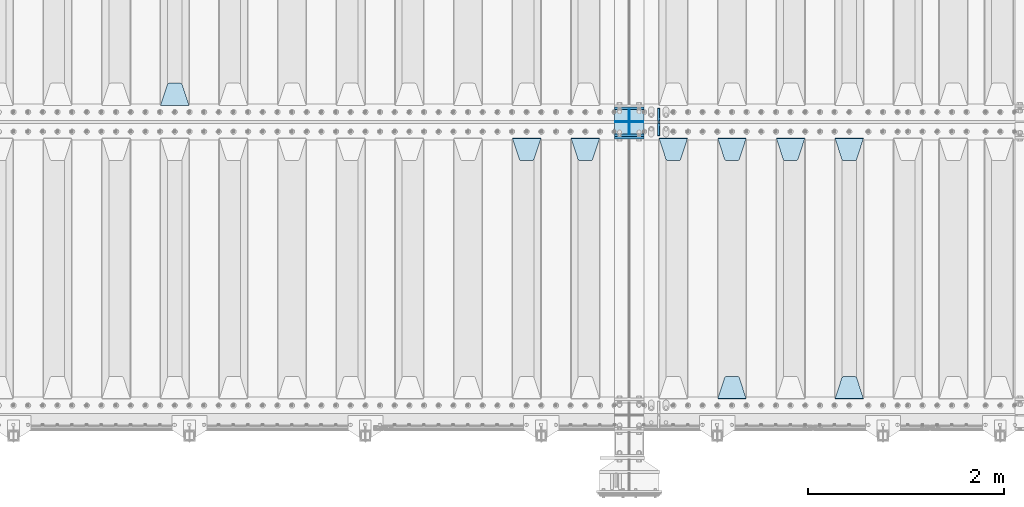
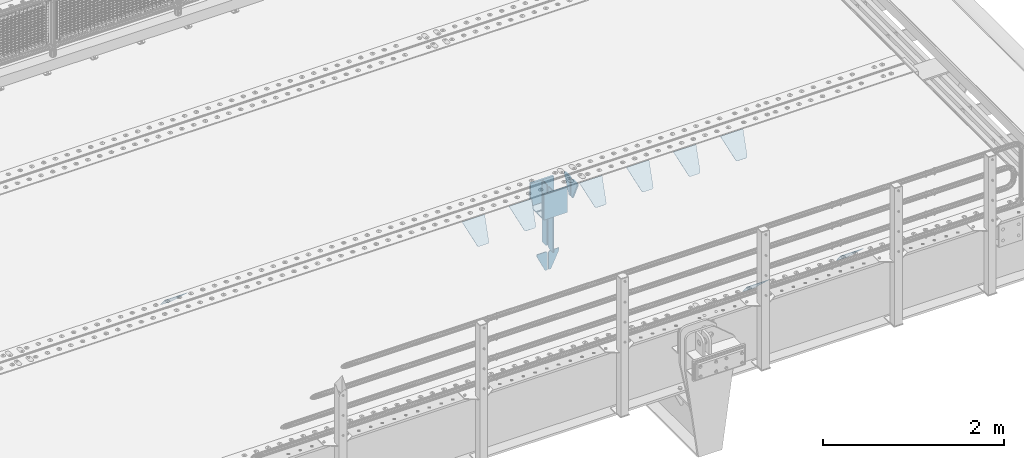
# One storey, part 207 of 247: 22 plates.
"""IFC2X3 building model written with IfcOpenShell, lengths in millimetres."""

from ifc_helpers import new_model, si_unit, frame, origin_with_axes, place, context, subcontext, project, spatial, faceted_brep, material, type_object, element, save


model = new_model("IFC2X3")

# Units and contexts
model_context = context("Model", 3, precision=1e-05, world=origin_with_axes())
body_context = subcontext(model_context, "Body", "Model", "MODEL_VIEW")
ifc_project = project(units=[si_unit("LENGTHUNIT", "METRE", prefix="MILLI"), si_unit("AREAUNIT", "SQUARE_METRE"), si_unit("VOLUMEUNIT", "CUBIC_METRE"), si_unit("MASSUNIT", "GRAM", prefix="KILO"), si_unit("TIMEUNIT", "SECOND"), si_unit("PLANEANGLEUNIT", "RADIAN"), si_unit("SOLIDANGLEUNIT", "STERADIAN"), si_unit("THERMODYNAMICTEMPERATUREUNIT", "DEGREE_CELSIUS"), si_unit("LUMINOUSINTENSITYUNIT", "LUMEN")], contexts=[model_context])

# Site, building, storey
site_placement = place(None, origin_with_axes())
site = spatial("IfcSite", under=ifc_project, at=site_placement, CompositionType="ELEMENT")
building_placement = place(site_placement, origin_with_axes())
building = spatial("IfcBuilding", under=site, at=building_placement, Name="Standard", CompositionType="ELEMENT")
storey_placement = place(building_placement, origin_with_axes())
storey = spatial("IfcBuildingStorey", under=building, at=storey_placement, Name="Undefined", CompositionType="ELEMENT", Elevation=0.0)

# Plates
ifc_material = material(Name="STEEL/S355N")
plate_type_1 = type_object("IfcPlateType", PredefinedType="NOTDEFINED")
for number, where, z_axis, x_axis in (
    (1, (12100.0, 3137.5, -340.0), (0.0, 0.0, 1.0), (1.0, 0.0, 0.0)),
    (2, (12100.0, 2862.5, -340.0), (0.0, 0.0, 1.0), (1.0, 0.0, 0.0)),
):
    element("IfcPlate", number, at=place(storey_placement, frame(where, z_axis=z_axis, x_axis=x_axis)), inside=storey, type_object=plate_type_1, material=ifc_material, context=body_context, shape_type="Brep", body=[
        faceted_brep([(0.0, -12.5, 0.0), (0.0, -12.5, 310.0), (0.0, 12.5, 310.0), (0.0, 12.5, 0.0), (300.0, -12.5, 310.0), (300.0, 12.5, 310.0), (300.0, -12.5, 0.0), (300.0, 12.5, 0.0)], [[[0, 1, 2, 3]], [[1, 4, 5, 2]], [[4, 6, 7, 5]], [[6, 0, 3, 7]], [[5, 7, 3, 2]], [[6, 4, 1, 0]]]),
    ])
plate_1_placement = place(storey_placement, frame((12100.0, 2837.5, -340.000000000044), z_axis=(0.0, 0.0, 1.0), x_axis=(1.0, 0.0, 0.0)))
element("IfcPlate", 3, at=plate_1_placement, inside=storey, type_object=plate_type_1, material=ifc_material, context=body_context, shape_type="Brep", body=[
    faceted_brep([(0.0, -12.5, 0.0), (0.0, -12.5, 340.0), (0.0, 12.5, 340.0), (0.0, 12.5, 0.0), (300.0, -12.5, 340.0), (300.0, 12.5, 340.0), (300.0, -12.5, 0.0), (300.0, 12.5, 0.0)], [[[0, 1, 2, 3]], [[1, 4, 5, 2]], [[4, 6, 7, 5]], [[6, 0, 3, 7]], [[5, 7, 3, 2]], [[6, 4, 1, 0]]]),
])
plate_type_2 = type_object("IfcPlateType", PredefinedType="NOTDEFINED")
for number, where, z_axis, x_axis in (
    (4, (12100.0, 2992.0, -343.0), (0.0, -0.999999999999548, -9.5100000000016e-07), (1.0, 0.0, 0.0)),
    (5, (12100.0, 3008.0, -343.0), (0.0, 1.0, 0.0), (1.0, 0.0, 0.0)),
):
    element("IfcPlate", number, at=place(storey_placement, frame(where, z_axis=z_axis, x_axis=x_axis)), inside=storey, type_object=plate_type_2, material=ifc_material, context=body_context, shape_type="Brep", body=[
        faceted_brep([(0.0, -7.0, 0.0), (0.0, -7.0, 117.0), (0.0, 7.0, 117.0), (0.0, 7.0, 0.0), (300.0, -7.0, 117.0), (300.0, 7.0, 117.0), (300.0, -7.0, 0.0), (300.0, 7.0, 0.0)], [[[0, 1, 2, 3]], [[1, 4, 5, 2]], [[4, 6, 7, 5]], [[6, 0, 3, 7]], [[5, 7, 3, 2]], [[6, 4, 1, 0]]]),
    ])
plate_type_3 = type_object("IfcPlateType", PredefinedType="NOTDEFINED")
for number, where, z_axis, x_axis in (
    (6, (12250.0, 2992.0, -350.0), (0.0, 0.0, -1.0), (0.0, -0.999999999999548, -9.5100000000016e-07)),
    (7, (12250.0, 3008.0, -350.0), (0.0, 0.0, -1.0), (0.0, 1.0, 0.0)),
):
    element("IfcPlate", number, at=place(storey_placement, frame(where, z_axis=z_axis, x_axis=x_axis)), inside=storey, type_object=plate_type_3, material=ifc_material, context=body_context, shape_type="Brep", body=[
        faceted_brep([(9.04219632502645e-09, -5.00000000143385, -2.89173840428703e-09), (0.0, -5.0, 480.0), (0.0, 5.0, 480.0), (7.66340235713869e-09, 4.99999999856618, -2.89173840428703e-09), (0.455767409633609, -5.0, 485.209445330008), (0.455767409633609, 5.0, 485.209445330008), (1.80922137642256, -5.0, 490.26060429977), (1.80922137642256, 5.0, 490.26060429977), (4.01923788646673, -5.0, 495.0), (4.01923788646673, 5.0, 495.0), (7.01866670643085, -5.0, 499.283628290596), (7.01866670643085, 5.0, 499.283628290596), (10.716371709404, -5.0, 502.981333293569), (10.716371709404, 5.0, 502.981333293569), (15.0, -5.0, 505.980762113533), (15.0, 5.0, 505.980762113533), (19.73939570023, -5.0, 508.190778623577), (19.73939570023, 5.0, 508.190778623577), (24.7905546699922, -5.0, 509.544232590366), (24.7905546699922, 5.0, 509.544232590366), (30.0, -5.0, 510.0), (30.0, 5.0, 510.0), (117.0, -5.0, 510.0), (117.0, 5.0, 510.0), (117.0, -5.0, 0.0), (117.0, 5.0, 0.0)], [[[0, 1, 2, 3]], [[1, 4, 5, 2]], [[4, 6, 7, 5]], [[6, 8, 9, 7]], [[8, 10, 11, 9]], [[10, 12, 13, 11]], [[12, 14, 15, 13]], [[14, 16, 17, 15]], [[16, 18, 19, 17]], [[18, 20, 21, 19]], [[20, 22, 23, 21]], [[22, 24, 25, 23]], [[24, 0, 3, 25]], [[5, 7, 9, 11, 13, 15, 17, 19, 21, 23, 25, 3, 2]], [[24, 22, 20, 18, 16, 14, 12, 10, 8, 6, 4, 1, 0]]]),
    ])
for number, where, z_axis, x_axis in (
    (8, (12250.0, 3008.0, -30.0), (0.0, 0.0, -1.0), (0.0, 1.0, 0.0)),
    (9, (12250.0, 2992.0, -30.0), (0.0, 0.0, -1.0), (0.0, -0.999999999999548, -9.5100000000016e-07)),
):
    element("IfcPlate", number, at=place(storey_placement, frame(where, z_axis=z_axis, x_axis=x_axis)), inside=storey, type_object=plate_type_3, material=ifc_material, context=body_context, shape_type="Brep", body=[
        faceted_brep([(0.0, -5.0, 30.0), (0.0, -5.0, 306.0), (0.0, 5.0, 306.0), (0.0, 5.0, 30.0), (117.0, -5.0, 306.0), (117.0, 5.0, 306.0), (117.0, -5.0, 0.0), (117.0, 5.0, 0.0), (30.0, -5.0, 0.0), (30.0, 5.0, 0.0), (24.7905546699922, -5.0, 0.455767409633758), (24.7905546699922, 5.0, 0.455767409633758), (19.73939570023, -5.0, 1.80922137642275), (19.73939570023, 5.0, 1.80922137642275), (15.0, -5.0, 4.01923788646684), (15.0, 5.0, 4.01923788646684), (10.716371709404, -5.0, 7.01866670643066), (10.716371709404, 5.0, 7.01866670643066), (7.01866670643085, -5.0, 10.7163717094038), (7.01866670643085, 5.0, 10.7163717094038), (4.01923788646673, -5.0, 15.0), (4.01923788646673, 5.0, 15.0), (1.80922137642256, -5.0, 19.7393957002299), (1.80922137642256, 5.0, 19.7393957002299), (0.455767409633609, -5.0, 24.7905546699921), (0.455767409633609, 5.0, 24.7905546699921)], [[[0, 1, 2, 3]], [[1, 4, 5, 2]], [[4, 6, 7, 5]], [[6, 8, 9, 7]], [[8, 10, 11, 9]], [[10, 12, 13, 11]], [[12, 14, 15, 13]], [[14, 16, 17, 15]], [[16, 18, 19, 17]], [[18, 20, 21, 19]], [[20, 22, 23, 21]], [[22, 24, 25, 23]], [[24, 0, 3, 25]], [[5, 7, 9, 11, 13, 15, 17, 19, 21, 23, 25, 3, 2]], [[24, 22, 20, 18, 16, 14, 12, 10, 8, 6, 4, 1, 0]]]),
    ])
plate_type_4 = type_object("IfcPlateType", PredefinedType="NOTDEFINED")
for number, where, z_axis, x_axis in (
    (10, (12243.5000000124, 2999.99999998464, -915.00001822257), (0.0, 0.0, -1.0), (-1.0, 0.0, 0.0)),
    (11, (12256.5000000124, 2999.99999998464, -915.00001822257), (0.0, 0.0, -1.0), (1.0, 0.0, 0.0)),
):
    element("IfcPlate", number, at=place(storey_placement, frame(where, z_axis=z_axis, x_axis=x_axis)), inside=storey, type_object=plate_type_4, material=ifc_material, context=body_context, shape_type="Brep", body=[
        faceted_brep([(0.0, -5.0, 27.0), (0.0, -5.0, 250.0), (0.0, 5.0, 250.0), (0.0, 5.0, 27.0), (30.0, -5.0, 250.0), (30.0, 5.0, 250.0), (135.0, -5.0, 30.0), (135.0, 5.0, 30.0), (135.0, -5.0, 0.0), (135.0, 5.0, 0.0), (27.0, -5.0, 0.0), (27.0, 5.0, 0.0), (22.3114992029932, -5.0, 0.410190668670339), (22.3114992029932, 5.0, 0.410190668670339), (17.7654561302061, -5.0, 1.62829923878041), (17.7654561302061, 5.0, 1.62829923878041), (13.5, -5.0, 3.61731409782021), (13.5, 5.0, 3.61731409782021), (9.64473453846404, -5.0, 6.31680003578765), (9.64473453846404, 5.0, 6.31680003578765), (6.31680003578731, -5.0, 9.64473453846347), (6.31680003578731, 5.0, 9.64473453846347), (3.61731409782078, -5.0, 13.5), (3.61731409782078, 5.0, 13.5), (1.62829923878053, -5.0, 17.765456130207), (1.62829923878053, 5.0, 17.765456130207), (0.410190668670111, -5.0, 22.3114992029929), (0.410190668670111, 5.0, 22.3114992029929)], [[[0, 1, 2, 3]], [[1, 4, 5, 2]], [[4, 6, 7, 5]], [[6, 8, 9, 7]], [[8, 10, 11, 9]], [[10, 12, 13, 11]], [[12, 14, 15, 13]], [[14, 16, 17, 15]], [[16, 18, 19, 17]], [[18, 20, 21, 19]], [[20, 22, 23, 21]], [[22, 24, 25, 23]], [[24, 26, 27, 25]], [[26, 0, 3, 27]], [[5, 7, 9, 11, 13, 15, 17, 19, 21, 23, 25, 27, 3, 2]], [[26, 24, 22, 20, 18, 16, 14, 12, 10, 8, 6, 4, 1, 0]]]),
    ])
plate_type_5 = type_object("IfcPlateType", PredefinedType="NOTDEFINED")
plate_2_placement = place(storey_placement, frame((14355.0, 2831.76776695594, -1.767766952965), z_axis=(0.0, -0.707106781186548, -0.707106781186547), x_axis=(1.0, 0.0, 0.0)))
element("IfcPlate", 12, at=plate_2_placement, inside=storey, type_object=plate_type_5, material=ifc_material, context=body_context, shape_type="Brep", body=[
    faceted_brep([(0.0, -2.49999999999909, 0.0), (69.345504679477, -2.5, 300.17173142483), (69.345504679477, 2.50000000000091, 300.171731424831), (0.0, 2.5, -9.09494701772928e-13), (70.9274061199576, -2.5, 304.897442415399), (70.9274061199576, 2.50000000000091, 304.8974424154), (73.3818627772307, -2.49999999999909, 309.234538108527), (73.3818627772307, 2.5, 309.234538108526), (76.6187032999551, -2.5, 313.023683126102), (76.6187032999551, 2.50000000000091, 313.023683126102), (80.5190132704993, -2.49999999999909, 316.125672595371), (80.5190132704993, 2.50000000000091, 316.125672595372), (84.9395038596849, -2.49999999999909, 318.426546230476), (84.9395038596849, 2.5, 318.426546230475), (89.7177759439219, -2.5, 319.841774983274), (89.7177759439219, 2.50000000000091, 319.841774983275), (94.678286292652, -2.5, 320.319366455077), (94.678286292652, 2.50000000000091, 320.319366455077), (195.321713707348, -2.5, 320.319366455077), (195.321713707348, 2.50000000000091, 320.319366455077), (200.282224056078, -2.5, 319.841774983274), (200.282224056078, 2.50000000000091, 319.841774983275), (205.060496140315, -2.5, 318.426546230475), (205.060496140315, 2.5, 318.426546230474), (209.480986729501, -2.49999999999818, 316.12567259537), (209.480986729501, 2.50000000000091, 316.12567259537), (213.381296700045, -2.5, 313.023683126101), (213.381296700045, 2.50000000000091, 313.023683126101), (216.618137222769, -2.5, 309.234538108525), (216.618137222769, 2.5, 309.234538108525), (219.072593880042, -2.49999999999909, 304.897442415398), (219.072593880042, 2.5, 304.897442415398), (220.654495320523, -2.5, 300.17173142483), (220.654495320523, 2.50000000000091, 300.171731424831), (290.0, -2.49999999999909, 0.0), (290.0, 2.5, -9.09494701772928e-13)], [[[0, 1, 2, 3]], [[1, 4, 5, 2]], [[4, 6, 7, 5]], [[6, 8, 9, 7]], [[8, 10, 11, 9]], [[10, 12, 13, 11]], [[12, 14, 15, 13]], [[14, 16, 17, 15]], [[16, 18, 19, 17]], [[18, 20, 21, 19]], [[20, 22, 23, 21]], [[22, 24, 25, 23]], [[24, 26, 27, 25]], [[26, 28, 29, 27]], [[28, 30, 31, 29]], [[30, 32, 33, 31]], [[32, 34, 35, 33]], [[34, 0, 3, 35]], [[5, 7, 9, 11, 13, 15, 17, 19, 21, 23, 25, 27, 29, 31, 33, 35, 3, 2]], [[34, 32, 30, 28, 26, 24, 22, 20, 18, 16, 14, 12, 10, 8, 6, 4, 1, 0]]]),
])
plate_3_placement = place(storey_placement, frame((14645.0, 168.232233047034, -1.76776695296758), z_axis=(0.0, 0.707106781186548, -0.707106781186547), x_axis=(-1.0, 0.0, 0.0)))
element("IfcPlate", 13, at=plate_3_placement, inside=storey, type_object=plate_type_5, material=ifc_material, context=body_context, shape_type="Brep", body=[
    faceted_brep([(0.0, -2.49999999999909, 0.0), (69.345504679477, -2.5, 300.17173142483), (69.345504679477, 2.50000000000091, 300.171731424831), (0.0, 2.5, -9.09494701772928e-13), (70.9274061199576, -2.5, 304.897442415399), (70.9274061199576, 2.50000000000091, 304.8974424154), (73.3818627772307, -2.49999999999909, 309.234538108527), (73.3818627772307, 2.5, 309.234538108526), (76.6187032999551, -2.5, 313.023683126102), (76.6187032999551, 2.50000000000091, 313.023683126102), (80.5190132704993, -2.49999999999909, 316.125672595371), (80.5190132704993, 2.50000000000091, 316.125672595372), (84.9395038596849, -2.49999999999909, 318.426546230476), (84.9395038596849, 2.5, 318.426546230475), (89.7177759439219, -2.5, 319.841774983274), (89.7177759439219, 2.50000000000091, 319.841774983275), (94.678286292652, -2.5, 320.319366455077), (94.678286292652, 2.50000000000091, 320.319366455077), (195.321713707348, -2.5, 320.319366455077), (195.321713707348, 2.50000000000091, 320.319366455077), (200.282224056078, -2.5, 319.841774983274), (200.282224056078, 2.50000000000091, 319.841774983275), (205.060496140315, -2.5, 318.426546230475), (205.060496140315, 2.5, 318.426546230474), (209.480986729501, -2.49999999999818, 316.12567259537), (209.480986729501, 2.50000000000091, 316.12567259537), (213.381296700045, -2.5, 313.023683126101), (213.381296700045, 2.50000000000091, 313.023683126101), (216.618137222769, -2.5, 309.234538108525), (216.618137222769, 2.5, 309.234538108525), (219.072593880042, -2.49999999999909, 304.897442415398), (219.072593880042, 2.5, 304.897442415398), (220.654495320523, -2.5, 300.17173142483), (220.654495320523, 2.50000000000091, 300.171731424831), (290.0, -2.49999999999909, 0.0), (290.0, 2.5, -9.09494701772928e-13)], [[[0, 1, 2, 3]], [[1, 4, 5, 2]], [[4, 6, 7, 5]], [[6, 8, 9, 7]], [[8, 10, 11, 9]], [[10, 12, 13, 11]], [[12, 14, 15, 13]], [[14, 16, 17, 15]], [[16, 18, 19, 17]], [[18, 20, 21, 19]], [[20, 22, 23, 21]], [[22, 24, 25, 23]], [[24, 26, 27, 25]], [[26, 28, 29, 27]], [[28, 30, 31, 29]], [[30, 32, 33, 31]], [[32, 34, 35, 33]], [[34, 0, 3, 35]], [[5, 7, 9, 11, 13, 15, 17, 19, 21, 23, 25, 27, 29, 31, 33, 35, 3, 2]], [[34, 32, 30, 28, 26, 24, 22, 20, 18, 16, 14, 12, 10, 8, 6, 4, 1, 0]]]),
])
plate_4_placement = place(storey_placement, frame((13755.0, 2831.76776695594, -1.767766952965), z_axis=(0.0, -0.707106781186548, -0.707106781186547), x_axis=(1.0, 0.0, 0.0)))
element("IfcPlate", 14, at=plate_4_placement, inside=storey, type_object=plate_type_5, material=ifc_material, context=body_context, shape_type="Brep", body=[
    faceted_brep([(0.0, -2.49999999999909, 0.0), (69.345504679477, -2.5, 300.17173142483), (69.345504679477, 2.50000000000091, 300.171731424831), (0.0, 2.5, -9.09494701772928e-13), (70.9274061199576, -2.5, 304.897442415399), (70.9274061199576, 2.50000000000091, 304.8974424154), (73.3818627772307, -2.49999999999909, 309.234538108527), (73.3818627772307, 2.5, 309.234538108526), (76.6187032999551, -2.5, 313.023683126102), (76.6187032999551, 2.50000000000091, 313.023683126102), (80.5190132704993, -2.49999999999909, 316.125672595371), (80.5190132704993, 2.50000000000091, 316.125672595372), (84.9395038596849, -2.49999999999909, 318.426546230476), (84.9395038596849, 2.5, 318.426546230475), (89.7177759439219, -2.5, 319.841774983274), (89.7177759439219, 2.50000000000091, 319.841774983275), (94.678286292652, -2.5, 320.319366455077), (94.678286292652, 2.50000000000091, 320.319366455077), (195.321713707348, -2.5, 320.319366455077), (195.321713707348, 2.50000000000091, 320.319366455077), (200.282224056078, -2.5, 319.841774983274), (200.282224056078, 2.50000000000091, 319.841774983275), (205.060496140315, -2.5, 318.426546230475), (205.060496140315, 2.5, 318.426546230474), (209.480986729501, -2.49999999999818, 316.12567259537), (209.480986729501, 2.50000000000091, 316.12567259537), (213.381296700045, -2.5, 313.023683126101), (213.381296700045, 2.50000000000091, 313.023683126101), (216.618137222769, -2.5, 309.234538108525), (216.618137222769, 2.5, 309.234538108525), (219.072593880042, -2.49999999999909, 304.897442415398), (219.072593880042, 2.5, 304.897442415398), (220.654495320523, -2.5, 300.17173142483), (220.654495320523, 2.50000000000091, 300.171731424831), (290.0, -2.49999999999909, 0.0), (290.0, 2.5, -9.09494701772928e-13)], [[[0, 1, 2, 3]], [[1, 4, 5, 2]], [[4, 6, 7, 5]], [[6, 8, 9, 7]], [[8, 10, 11, 9]], [[10, 12, 13, 11]], [[12, 14, 15, 13]], [[14, 16, 17, 15]], [[16, 18, 19, 17]], [[18, 20, 21, 19]], [[20, 22, 23, 21]], [[22, 24, 25, 23]], [[24, 26, 27, 25]], [[26, 28, 29, 27]], [[28, 30, 31, 29]], [[30, 32, 33, 31]], [[32, 34, 35, 33]], [[34, 0, 3, 35]], [[5, 7, 9, 11, 13, 15, 17, 19, 21, 23, 25, 27, 29, 31, 33, 35, 3, 2]], [[34, 32, 30, 28, 26, 24, 22, 20, 18, 16, 14, 12, 10, 8, 6, 4, 1, 0]]]),
])
plate_5_placement = place(storey_placement, frame((13155.0, 2831.76776695594, -1.767766952965), z_axis=(0.0, -0.707106781186548, -0.707106781186547), x_axis=(1.0, 0.0, 0.0)))
element("IfcPlate", 15, at=plate_5_placement, inside=storey, type_object=plate_type_5, material=ifc_material, context=body_context, shape_type="Brep", body=[
    faceted_brep([(0.0, -2.49999999999909, 0.0), (69.345504679477, -2.5, 300.17173142483), (69.345504679477, 2.50000000000091, 300.171731424831), (0.0, 2.5, -9.09494701772928e-13), (70.9274061199576, -2.5, 304.897442415399), (70.9274061199576, 2.50000000000091, 304.8974424154), (73.3818627772307, -2.49999999999909, 309.234538108527), (73.3818627772307, 2.5, 309.234538108526), (76.6187032999551, -2.5, 313.023683126102), (76.6187032999551, 2.50000000000091, 313.023683126102), (80.5190132704993, -2.49999999999909, 316.125672595371), (80.5190132704993, 2.50000000000091, 316.125672595372), (84.9395038596849, -2.49999999999909, 318.426546230476), (84.9395038596849, 2.5, 318.426546230475), (89.7177759439219, -2.5, 319.841774983274), (89.7177759439219, 2.50000000000091, 319.841774983275), (94.678286292652, -2.5, 320.319366455077), (94.678286292652, 2.50000000000091, 320.319366455077), (195.321713707348, -2.5, 320.319366455077), (195.321713707348, 2.50000000000091, 320.319366455077), (200.282224056078, -2.5, 319.841774983274), (200.282224056078, 2.50000000000091, 319.841774983275), (205.060496140315, -2.5, 318.426546230475), (205.060496140315, 2.5, 318.426546230474), (209.480986729501, -2.49999999999818, 316.12567259537), (209.480986729501, 2.50000000000091, 316.12567259537), (213.381296700045, -2.5, 313.023683126101), (213.381296700045, 2.50000000000091, 313.023683126101), (216.618137222769, -2.5, 309.234538108525), (216.618137222769, 2.5, 309.234538108525), (219.072593880042, -2.49999999999909, 304.897442415398), (219.072593880042, 2.5, 304.897442415398), (220.654495320523, -2.5, 300.17173142483), (220.654495320523, 2.50000000000091, 300.171731424831), (290.0, -2.49999999999909, 0.0), (290.0, 2.5, -9.09494701772928e-13)], [[[0, 1, 2, 3]], [[1, 4, 5, 2]], [[4, 6, 7, 5]], [[6, 8, 9, 7]], [[8, 10, 11, 9]], [[10, 12, 13, 11]], [[12, 14, 15, 13]], [[14, 16, 17, 15]], [[16, 18, 19, 17]], [[18, 20, 21, 19]], [[20, 22, 23, 21]], [[22, 24, 25, 23]], [[24, 26, 27, 25]], [[26, 28, 29, 27]], [[28, 30, 31, 29]], [[30, 32, 33, 31]], [[32, 34, 35, 33]], [[34, 0, 3, 35]], [[5, 7, 9, 11, 13, 15, 17, 19, 21, 23, 25, 27, 29, 31, 33, 35, 3, 2]], [[34, 32, 30, 28, 26, 24, 22, 20, 18, 16, 14, 12, 10, 8, 6, 4, 1, 0]]]),
])
plate_6_placement = place(storey_placement, frame((13445.0, 168.232233047034, -1.76776695296758), z_axis=(0.0, 0.707106781186548, -0.707106781186547), x_axis=(-1.0, 0.0, 0.0)))
element("IfcPlate", 16, at=plate_6_placement, inside=storey, type_object=plate_type_5, material=ifc_material, context=body_context, shape_type="Brep", body=[
    faceted_brep([(0.0, -2.49999999999909, 0.0), (69.345504679477, -2.5, 300.17173142483), (69.345504679477, 2.50000000000091, 300.171731424831), (0.0, 2.5, -9.09494701772928e-13), (70.9274061199576, -2.5, 304.897442415399), (70.9274061199576, 2.50000000000091, 304.8974424154), (73.3818627772307, -2.49999999999909, 309.234538108527), (73.3818627772307, 2.5, 309.234538108526), (76.6187032999551, -2.5, 313.023683126102), (76.6187032999551, 2.50000000000091, 313.023683126102), (80.5190132704993, -2.49999999999909, 316.125672595371), (80.5190132704993, 2.50000000000091, 316.125672595372), (84.9395038596849, -2.49999999999909, 318.426546230476), (84.9395038596849, 2.5, 318.426546230475), (89.7177759439219, -2.5, 319.841774983274), (89.7177759439219, 2.50000000000091, 319.841774983275), (94.678286292652, -2.5, 320.319366455077), (94.678286292652, 2.50000000000091, 320.319366455077), (195.321713707348, -2.5, 320.319366455077), (195.321713707348, 2.50000000000091, 320.319366455077), (200.282224056078, -2.5, 319.841774983274), (200.282224056078, 2.50000000000091, 319.841774983275), (205.060496140315, -2.5, 318.426546230475), (205.060496140315, 2.5, 318.426546230474), (209.480986729501, -2.49999999999818, 316.12567259537), (209.480986729501, 2.50000000000091, 316.12567259537), (213.381296700045, -2.5, 313.023683126101), (213.381296700045, 2.50000000000091, 313.023683126101), (216.618137222769, -2.5, 309.234538108525), (216.618137222769, 2.5, 309.234538108525), (219.072593880042, -2.49999999999909, 304.897442415398), (219.072593880042, 2.5, 304.897442415398), (220.654495320523, -2.5, 300.17173142483), (220.654495320523, 2.50000000000091, 300.171731424831), (290.0, -2.49999999999909, 0.0), (290.0, 2.5, -9.09494701772928e-13)], [[[0, 1, 2, 3]], [[1, 4, 5, 2]], [[4, 6, 7, 5]], [[6, 8, 9, 7]], [[8, 10, 11, 9]], [[10, 12, 13, 11]], [[12, 14, 15, 13]], [[14, 16, 17, 15]], [[16, 18, 19, 17]], [[18, 20, 21, 19]], [[20, 22, 23, 21]], [[22, 24, 25, 23]], [[24, 26, 27, 25]], [[26, 28, 29, 27]], [[28, 30, 31, 29]], [[30, 32, 33, 31]], [[32, 34, 35, 33]], [[34, 0, 3, 35]], [[5, 7, 9, 11, 13, 15, 17, 19, 21, 23, 25, 27, 29, 31, 33, 35, 3, 2]], [[34, 32, 30, 28, 26, 24, 22, 20, 18, 16, 14, 12, 10, 8, 6, 4, 1, 0]]]),
])
plate_7_placement = place(storey_placement, frame((12555.0, 2831.76776695594, -1.767766952965), z_axis=(0.0, -0.707106781186548, -0.707106781186547), x_axis=(1.0, 0.0, 0.0)))
element("IfcPlate", 17, at=plate_7_placement, inside=storey, type_object=plate_type_5, material=ifc_material, context=body_context, shape_type="Brep", body=[
    faceted_brep([(0.0, -2.49999999999909, 0.0), (69.345504679477, -2.5, 300.17173142483), (69.345504679477, 2.50000000000091, 300.171731424831), (0.0, 2.5, -9.09494701772928e-13), (70.9274061199576, -2.5, 304.897442415399), (70.9274061199576, 2.50000000000091, 304.8974424154), (73.3818627772307, -2.49999999999909, 309.234538108527), (73.3818627772307, 2.5, 309.234538108526), (76.6187032999551, -2.5, 313.023683126102), (76.6187032999551, 2.50000000000091, 313.023683126102), (80.5190132704993, -2.49999999999909, 316.125672595371), (80.5190132704993, 2.50000000000091, 316.125672595372), (84.9395038596849, -2.49999999999909, 318.426546230476), (84.9395038596849, 2.5, 318.426546230475), (89.7177759439219, -2.5, 319.841774983274), (89.7177759439219, 2.50000000000091, 319.841774983275), (94.678286292652, -2.5, 320.319366455077), (94.678286292652, 2.50000000000091, 320.319366455077), (195.321713707348, -2.5, 320.319366455077), (195.321713707348, 2.50000000000091, 320.319366455077), (200.282224056078, -2.5, 319.841774983274), (200.282224056078, 2.50000000000091, 319.841774983275), (205.060496140315, -2.5, 318.426546230475), (205.060496140315, 2.5, 318.426546230474), (209.480986729501, -2.49999999999818, 316.12567259537), (209.480986729501, 2.50000000000091, 316.12567259537), (213.381296700045, -2.5, 313.023683126101), (213.381296700045, 2.50000000000091, 313.023683126101), (216.618137222769, -2.5, 309.234538108525), (216.618137222769, 2.5, 309.234538108525), (219.072593880042, -2.49999999999909, 304.897442415398), (219.072593880042, 2.5, 304.897442415398), (220.654495320523, -2.5, 300.17173142483), (220.654495320523, 2.50000000000091, 300.171731424831), (290.0, -2.49999999999909, 0.0), (290.0, 2.5, -9.09494701772928e-13)], [[[0, 1, 2, 3]], [[1, 4, 5, 2]], [[4, 6, 7, 5]], [[6, 8, 9, 7]], [[8, 10, 11, 9]], [[10, 12, 13, 11]], [[12, 14, 15, 13]], [[14, 16, 17, 15]], [[16, 18, 19, 17]], [[18, 20, 21, 19]], [[20, 22, 23, 21]], [[22, 24, 25, 23]], [[24, 26, 27, 25]], [[26, 28, 29, 27]], [[28, 30, 31, 29]], [[30, 32, 33, 31]], [[32, 34, 35, 33]], [[34, 0, 3, 35]], [[5, 7, 9, 11, 13, 15, 17, 19, 21, 23, 25, 27, 29, 31, 33, 35, 3, 2]], [[34, 32, 30, 28, 26, 24, 22, 20, 18, 16, 14, 12, 10, 8, 6, 4, 1, 0]]]),
])
plate_8_placement = place(storey_placement, frame((11655.0, 2831.76776695594, -1.767766952965), z_axis=(0.0, -0.707106781186548, -0.707106781186547), x_axis=(1.0, 0.0, 0.0)))
element("IfcPlate", 18, at=plate_8_placement, inside=storey, type_object=plate_type_5, material=ifc_material, context=body_context, shape_type="Brep", body=[
    faceted_brep([(0.0, -2.49999999999909, 0.0), (69.345504679477, -2.5, 300.17173142483), (69.345504679477, 2.50000000000091, 300.171731424831), (0.0, 2.5, -9.09494701772928e-13), (70.9274061199576, -2.5, 304.897442415399), (70.9274061199576, 2.50000000000091, 304.8974424154), (73.3818627772307, -2.49999999999909, 309.234538108527), (73.3818627772307, 2.5, 309.234538108526), (76.6187032999551, -2.5, 313.023683126102), (76.6187032999551, 2.50000000000091, 313.023683126102), (80.5190132704993, -2.49999999999909, 316.125672595371), (80.5190132704993, 2.50000000000091, 316.125672595372), (84.9395038596849, -2.49999999999909, 318.426546230476), (84.9395038596849, 2.5, 318.426546230475), (89.7177759439219, -2.5, 319.841774983274), (89.7177759439219, 2.50000000000091, 319.841774983275), (94.678286292652, -2.5, 320.319366455077), (94.678286292652, 2.50000000000091, 320.319366455077), (195.321713707348, -2.5, 320.319366455077), (195.321713707348, 2.50000000000091, 320.319366455077), (200.282224056078, -2.5, 319.841774983274), (200.282224056078, 2.50000000000091, 319.841774983275), (205.060496140315, -2.5, 318.426546230475), (205.060496140315, 2.5, 318.426546230474), (209.480986729501, -2.49999999999818, 316.12567259537), (209.480986729501, 2.50000000000091, 316.12567259537), (213.381296700045, -2.5, 313.023683126101), (213.381296700045, 2.50000000000091, 313.023683126101), (216.618137222769, -2.5, 309.234538108525), (216.618137222769, 2.5, 309.234538108525), (219.072593880042, -2.49999999999909, 304.897442415398), (219.072593880042, 2.5, 304.897442415398), (220.654495320523, -2.5, 300.17173142483), (220.654495320523, 2.50000000000091, 300.171731424831), (290.0, -2.49999999999909, 0.0), (290.0, 2.5, -9.09494701772928e-13)], [[[0, 1, 2, 3]], [[1, 4, 5, 2]], [[4, 6, 7, 5]], [[6, 8, 9, 7]], [[8, 10, 11, 9]], [[10, 12, 13, 11]], [[12, 14, 15, 13]], [[14, 16, 17, 15]], [[16, 18, 19, 17]], [[18, 20, 21, 19]], [[20, 22, 23, 21]], [[22, 24, 25, 23]], [[24, 26, 27, 25]], [[26, 28, 29, 27]], [[28, 30, 31, 29]], [[30, 32, 33, 31]], [[32, 34, 35, 33]], [[34, 0, 3, 35]], [[5, 7, 9, 11, 13, 15, 17, 19, 21, 23, 25, 27, 29, 31, 33, 35, 3, 2]], [[34, 32, 30, 28, 26, 24, 22, 20, 18, 16, 14, 12, 10, 8, 6, 4, 1, 0]]]),
])
plate_9_placement = place(storey_placement, frame((11055.0, 2831.76776695594, -1.767766952965), z_axis=(0.0, -0.707106781186548, -0.707106781186547), x_axis=(1.0, 0.0, 0.0)))
element("IfcPlate", 19, at=plate_9_placement, inside=storey, type_object=plate_type_5, material=ifc_material, context=body_context, shape_type="Brep", body=[
    faceted_brep([(0.0, -2.49999999999909, 0.0), (69.345504679477, -2.5, 300.17173142483), (69.345504679477, 2.50000000000091, 300.171731424831), (0.0, 2.5, -9.09494701772928e-13), (70.9274061199576, -2.5, 304.897442415399), (70.9274061199576, 2.50000000000091, 304.8974424154), (73.3818627772307, -2.49999999999909, 309.234538108527), (73.3818627772307, 2.5, 309.234538108526), (76.6187032999551, -2.5, 313.023683126102), (76.6187032999551, 2.50000000000091, 313.023683126102), (80.5190132704993, -2.49999999999909, 316.125672595371), (80.5190132704993, 2.50000000000091, 316.125672595372), (84.9395038596849, -2.49999999999909, 318.426546230476), (84.9395038596849, 2.5, 318.426546230475), (89.7177759439219, -2.5, 319.841774983274), (89.7177759439219, 2.50000000000091, 319.841774983275), (94.678286292652, -2.5, 320.319366455077), (94.678286292652, 2.50000000000091, 320.319366455077), (195.321713707348, -2.5, 320.319366455077), (195.321713707348, 2.50000000000091, 320.319366455077), (200.282224056078, -2.5, 319.841774983274), (200.282224056078, 2.50000000000091, 319.841774983275), (205.060496140315, -2.5, 318.426546230475), (205.060496140315, 2.5, 318.426546230474), (209.480986729501, -2.49999999999818, 316.12567259537), (209.480986729501, 2.50000000000091, 316.12567259537), (213.381296700045, -2.5, 313.023683126101), (213.381296700045, 2.50000000000091, 313.023683126101), (216.618137222769, -2.5, 309.234538108525), (216.618137222769, 2.5, 309.234538108525), (219.072593880042, -2.49999999999909, 304.897442415398), (219.072593880042, 2.5, 304.897442415398), (220.654495320523, -2.5, 300.17173142483), (220.654495320523, 2.50000000000091, 300.171731424831), (290.0, -2.49999999999909, 0.0), (290.0, 2.5, -9.09494701772928e-13)], [[[0, 1, 2, 3]], [[1, 4, 5, 2]], [[4, 6, 7, 5]], [[6, 8, 9, 7]], [[8, 10, 11, 9]], [[10, 12, 13, 11]], [[12, 14, 15, 13]], [[14, 16, 17, 15]], [[16, 18, 19, 17]], [[18, 20, 21, 19]], [[20, 22, 23, 21]], [[22, 24, 25, 23]], [[24, 26, 27, 25]], [[26, 28, 29, 27]], [[28, 30, 31, 29]], [[30, 32, 33, 31]], [[32, 34, 35, 33]], [[34, 0, 3, 35]], [[5, 7, 9, 11, 13, 15, 17, 19, 21, 23, 25, 27, 29, 31, 33, 35, 3, 2]], [[34, 32, 30, 28, 26, 24, 22, 20, 18, 16, 14, 12, 10, 8, 6, 4, 1, 0]]]),
])
plate_10_placement = place(storey_placement, frame((7745.0, 3168.23223304703, -1.76776695296758), z_axis=(0.0, 0.707106781186548, -0.707106781186547), x_axis=(-1.0, 0.0, 0.0)))
element("IfcPlate", 20, at=plate_10_placement, inside=storey, type_object=plate_type_5, material=ifc_material, context=body_context, shape_type="Brep", body=[
    faceted_brep([(0.0, -2.49999999999909, 0.0), (69.345504679477, -2.5, 300.17173142483), (69.345504679477, 2.50000000000091, 300.171731424831), (0.0, 2.5, -9.09494701772928e-13), (70.9274061199576, -2.5, 304.897442415399), (70.9274061199576, 2.50000000000091, 304.8974424154), (73.3818627772307, -2.49999999999909, 309.234538108527), (73.3818627772307, 2.5, 309.234538108526), (76.6187032999551, -2.5, 313.023683126102), (76.6187032999551, 2.50000000000091, 313.023683126102), (80.5190132704993, -2.49999999999909, 316.125672595371), (80.5190132704993, 2.50000000000091, 316.125672595372), (84.9395038596849, -2.49999999999909, 318.426546230476), (84.9395038596849, 2.5, 318.426546230475), (89.7177759439219, -2.5, 319.841774983274), (89.7177759439219, 2.50000000000091, 319.841774983275), (94.678286292652, -2.5, 320.319366455077), (94.678286292652, 2.50000000000091, 320.319366455077), (195.321713707348, -2.5, 320.319366455077), (195.321713707348, 2.50000000000091, 320.319366455077), (200.282224056078, -2.5, 319.841774983274), (200.282224056078, 2.50000000000091, 319.841774983275), (205.060496140315, -2.5, 318.426546230475), (205.060496140315, 2.5, 318.426546230474), (209.480986729501, -2.49999999999818, 316.12567259537), (209.480986729501, 2.50000000000091, 316.12567259537), (213.381296700045, -2.5, 313.023683126101), (213.381296700045, 2.50000000000091, 313.023683126101), (216.618137222769, -2.5, 309.234538108525), (216.618137222769, 2.5, 309.234538108525), (219.072593880042, -2.49999999999909, 304.897442415398), (219.072593880042, 2.5, 304.897442415398), (220.654495320523, -2.5, 300.17173142483), (220.654495320523, 2.50000000000091, 300.171731424831), (290.0, -2.49999999999909, 0.0), (290.0, 2.5, -9.09494701772928e-13)], [[[0, 1, 2, 3]], [[1, 4, 5, 2]], [[4, 6, 7, 5]], [[6, 8, 9, 7]], [[8, 10, 11, 9]], [[10, 12, 13, 11]], [[12, 14, 15, 13]], [[14, 16, 17, 15]], [[16, 18, 19, 17]], [[18, 20, 21, 19]], [[20, 22, 23, 21]], [[22, 24, 25, 23]], [[24, 26, 27, 25]], [[26, 28, 29, 27]], [[28, 30, 31, 29]], [[30, 32, 33, 31]], [[32, 34, 35, 33]], [[34, 0, 3, 35]], [[5, 7, 9, 11, 13, 15, 17, 19, 21, 23, 25, 27, 29, 31, 33, 35, 3, 2]], [[34, 32, 30, 28, 26, 24, 22, 20, 18, 16, 14, 12, 10, 8, 6, 4, 1, 0]]]),
])
plate_type_6 = type_object("IfcPlateType", PredefinedType="NOTDEFINED")
for number, where, z_axis, x_axis in (
    (21, (12550.0, 2860.0, -30.0), (0.0, 0.0, -1.0), (0.0, 1.0, 0.0)),
    (22, (12550.0, 3140.0, -30.0), (0.0, 0.0, -1.0), (0.0, -0.999999999999548, -9.5100000000016e-07)),
):
    element("IfcPlate", number, at=place(storey_placement, frame(where, z_axis=z_axis, x_axis=x_axis)), inside=storey, type_object=plate_type_6, material=ifc_material, context=body_context, shape_type="Brep", body=[
        faceted_brep([(-5.6843418860808e-14, -9.99999999999989, 3.5527136788005e-15), (0.0, -10.0, 30.0), (0.0, 10.0, 30.0), (-5.6843418860808e-14, 10.0000000000001, 3.5527136788005e-15), (102.0, -10.0, 250.0), (102.0, 10.0, 250.0), (132.0, -10.0, 250.0), (132.0, 10.0, 250.0), (132.0, -10.0, 30.0), (132.0, 10.0, 30.0), (131.544232590366, -10.0, 24.790554669992), (131.544232590366, 10.0, 24.790554669992), (130.190778623577, -10.0, 19.7393957002299), (130.190778623577, 10.0, 19.7393957002299), (127.980762113533, -10.0, 15.0), (127.980762113533, 10.0, 15.0), (124.981333293569, -10.0, 10.7163717094038), (124.981333293569, 10.0, 10.7163717094038), (121.283628290596, -10.0, 7.01866670643062), (121.283628290596, 10.0, 7.01866670643062), (117.0, -10.0, 4.01923788646684), (117.0, 10.0, 4.01923788646684), (112.26060429977, -10.0, 1.80922137642278), (112.26060429977, 10.0, 1.80922137642278), (107.209445330008, -10.0, 0.455767409633722), (107.209445330008, 10.0, 0.455767409633722), (102.0, -10.0, 0.0), (102.0, 10.0, 0.0)], [[[0, 1, 2, 3]], [[1, 4, 5, 2]], [[4, 6, 7, 5]], [[6, 8, 9, 7]], [[8, 10, 11, 9]], [[10, 12, 13, 11]], [[12, 14, 15, 13]], [[14, 16, 17, 15]], [[16, 18, 19, 17]], [[18, 20, 21, 19]], [[20, 22, 23, 21]], [[22, 24, 25, 23]], [[24, 26, 27, 25]], [[26, 0, 3, 27]], [[5, 7, 9, 11, 13, 15, 17, 19, 21, 23, 25, 27, 3, 2]], [[26, 24, 22, 20, 18, 16, 14, 12, 10, 8, 6, 4, 1, 0]]]),
    ])

save(model, "model.ifc")
